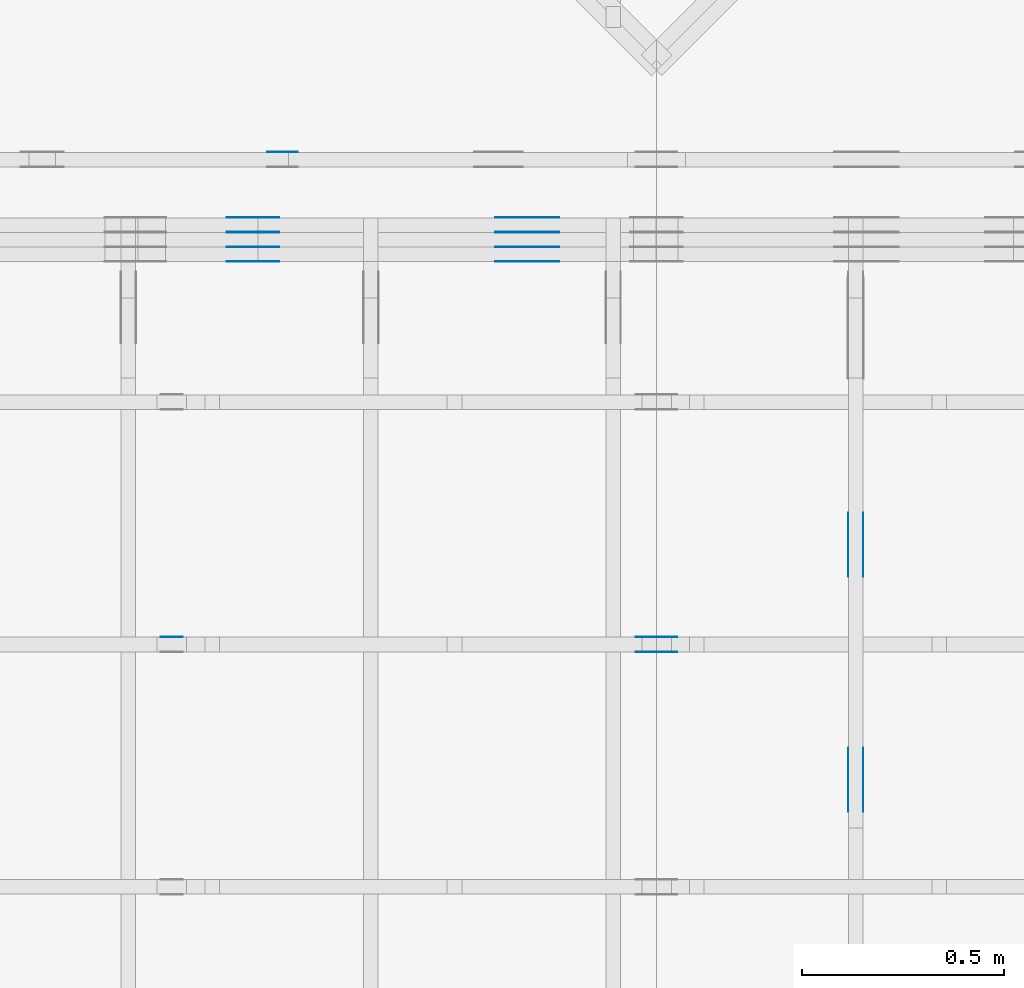
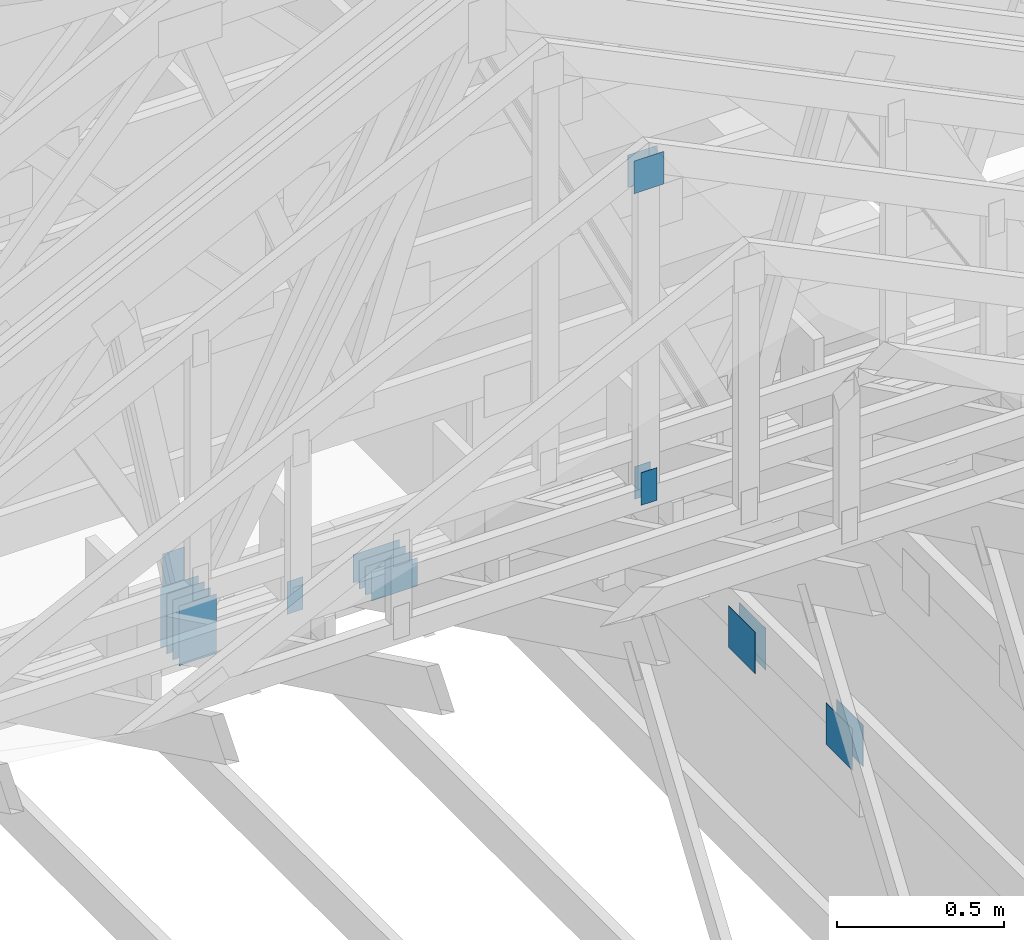
# One storey, part 102 of 159: 22 plates, 4 elements without a shape of their own.
"""IFC2X3 building model written with IfcOpenShell, lengths in millimetres."""

from ifc_helpers import new_model, si_unit, frame, origin, origin_with_axes, origin_2d, place, context, project, spatial, faceted_brep, element, aggregate, save


model = new_model("IFC2X3")

# Units and contexts
model_context = context("Model", 3, precision=1e-05, world=origin())
plan_context = context("Plan", 2, precision=1e-05, world=origin_2d())
ifc_project = project(units=[si_unit("LENGTHUNIT", "METRE", prefix="MILLI"), si_unit("AREAUNIT", "SQUARE_METRE"), si_unit("VOLUMEUNIT", "CUBIC_METRE"), si_unit("SOLIDANGLEUNIT", "STERADIAN"), si_unit("PLANEANGLEUNIT", "RADIAN"), si_unit("MASSUNIT", "GRAM"), si_unit("TIMEUNIT", "SECOND"), si_unit("THERMODYNAMICTEMPERATUREUNIT", "DEGREE_CELSIUS"), si_unit("LUMINOUSINTENSITYUNIT", "LUMEN")], contexts=[model_context, plan_context])

# Site, building, storey
site_placement = place(None, origin_with_axes())
site = spatial("IfcSite", under=ifc_project, at=site_placement, CompositionType="ELEMENT")
building_placement = place(site_placement, origin_with_axes())
building = spatial("IfcBuilding", under=site, at=building_placement, Name="Plan 1", CompositionType="ELEMENT")
storey_placement = place(building_placement, origin_with_axes())
storey = spatial("IfcBuildingStorey", under=building, at=storey_placement, Name="Etasje 1", CompositionType="ELEMENT", Elevation=0.0)

# Assembly, plates
assembly_1_placement = place(storey_placement, frame((10700.012663101485, 8801.999999990367, 0.0), z_axis=(0.0, -1.0, 6.123031769111886e-17), x_axis=(1.0, 0.0, 0.0)))
assembly_1 = element("IfcElementAssembly", 1, at=assembly_1_placement, inside=storey, Name="T8 (1)", AssemblyPlace="FACTORY", PredefinedType="TRUSS")
plate_1_placement = place(assembly_1_placement, frame((3659.5000000000005, 348.5, 0.0), z_axis=(0.0, 0.0, 1.0), x_axis=(-1.0, 1.2246063538223773e-16, 0.0)))
plate_1 = element("IfcPlate", 2, at=plate_1_placement, Name="GNT100S 103x159", context=model_context, shape_type="Brep", body=[
    faceted_brep([(159.00000000000045, 103.0, 1.0), (4.547473508864641e-13, 103.0, 1.0), (4.547473508864641e-13, 0.0, 1.0), (159.00000000000045, 0.0, 1.0), (4.547473508864641e-13, 103.0, 5.56886495279458e-29), (159.00000000000045, 103.0, 1.9471241025775855e-14), (159.00000000000045, 0.0, 1.9471241025775855e-14), (4.547473508864641e-13, 0.0, 5.56886495279458e-29), (159.0, 3.118536516261844e-13, 1.788345410772899e-30), (159.0, 3.119148819438755e-13, 1.0), (1.1247455413666031e-32, 3.411217434825392e-13, 1.0), (0.0, 3.410605131648481e-13, 0.0), (159.0, 103.00000000000037, 0.0), (159.0, 103.00000000000037, 1.0), (159.0, 3.410605131648481e-13, 1.0), (159.0, 3.410605131648481e-13, 0.0), (0.0, 103.00000000000034, 0.0), (0.0, 103.00000000000034, 1.0), (159.0, 103.00000000000037, 1.0), (159.0, 103.00000000000037, -7.888609052210118e-31), (4.176648714595935e-29, 3.410605131648481e-13, -2.5573752767891235e-45), (6.123031769116062e-17, 3.410605131648481e-13, 1.0), (1.2674675762061646e-14, 103.00000000000034, 1.0), (1.2613445444370527e-14, 103.00000000000034, -7.723252717384033e-31)], [[[0, 1, 2, 3]], [[4, 5, 6, 7]], [[8, 9, 10, 11]], [[12, 13, 14, 15]], [[16, 17, 18, 19]], [[20, 21, 22, 23]]]),
])
plate_2_placement = place(assembly_1_placement, frame((3659.5000000000005, 348.5, -37.0), z_axis=(0.0, 0.0, 1.0), x_axis=(-1.0, 1.2246063538223773e-16, 0.0)))
plate_2 = element("IfcPlate", 3, at=plate_2_placement, Name="GNT100S 103x159", context=model_context, shape_type="Brep", body=[
    faceted_brep([(159.00000000000045, 103.0, 1.0), (4.547473508864641e-13, 103.0, 1.0), (4.547473508864641e-13, 0.0, 1.0), (159.00000000000045, 0.0, 1.0), (4.547473508864641e-13, 103.0, 5.56886495279458e-29), (159.00000000000045, 103.0, 1.9471241025775855e-14), (159.00000000000045, 0.0, 1.9471241025775855e-14), (4.547473508864641e-13, 0.0, 5.56886495279458e-29), (159.0, 3.118536516261844e-13, 1.788345410772899e-30), (159.0, 3.119148819438755e-13, 1.0), (1.1247455413666031e-32, 3.411217434825392e-13, 1.0), (0.0, 3.410605131648481e-13, 0.0), (159.0, 103.00000000000037, 0.0), (159.0, 103.00000000000037, 1.0), (159.0, 3.410605131648481e-13, 1.0), (159.0, 3.410605131648481e-13, 0.0), (0.0, 103.00000000000034, 0.0), (0.0, 103.00000000000034, 1.0), (159.0, 103.00000000000037, 1.0), (159.0, 103.00000000000037, -7.888609052210118e-31), (4.176648714595935e-29, 3.410605131648481e-13, -2.5573752767891235e-45), (6.123031769116062e-17, 3.410605131648481e-13, 1.0), (1.2674675762061646e-14, 103.00000000000034, 1.0), (1.2613445444370527e-14, 103.00000000000034, -7.723252717384033e-31)], [[[0, 1, 2, 3]], [[4, 5, 6, 7]], [[8, 9, 10, 11]], [[12, 13, 14, 15]], [[16, 17, 18, 19]], [[20, 21, 22, 23]]]),
])
plate_3_placement = place(assembly_1_placement, frame((3659.5000000000005, 348.5, -36.0), z_axis=(0.0, 0.0, 1.0), x_axis=(-1.0, 1.2246063538223773e-16, 0.0)))
plate_3 = element("IfcPlate", 4, at=plate_3_placement, Name="GNT100S 103x159", context=model_context, shape_type="Brep", body=[
    faceted_brep([(159.00000000000045, 103.0, 1.0), (4.547473508864641e-13, 103.0, 1.0), (4.547473508864641e-13, 0.0, 1.0), (159.00000000000045, 0.0, 1.0), (4.547473508864641e-13, 103.0, 5.56886495279458e-29), (159.00000000000045, 103.0, 1.9471241025775855e-14), (159.00000000000045, 0.0, 1.9471241025775855e-14), (4.547473508864641e-13, 0.0, 5.56886495279458e-29), (159.0, 3.118536516261844e-13, 1.788345410772899e-30), (159.0, 3.119148819438755e-13, 1.0), (1.1247455413666031e-32, 3.411217434825392e-13, 1.0), (0.0, 3.410605131648481e-13, 0.0), (159.0, 103.00000000000037, 0.0), (159.0, 103.00000000000037, 1.0), (159.0, 3.410605131648481e-13, 1.0), (159.0, 3.410605131648481e-13, 0.0), (0.0, 103.00000000000034, 0.0), (0.0, 103.00000000000034, 1.0), (159.0, 103.00000000000037, 1.0), (159.0, 103.00000000000037, -7.888609052210118e-31), (4.176648714595935e-29, 3.410605131648481e-13, -2.5573752767891235e-45), (6.123031769116062e-17, 3.410605131648481e-13, 1.0), (1.2674675762061646e-14, 103.00000000000034, 1.0), (1.2613445444370527e-14, 103.00000000000034, -7.723252717384033e-31)], [[[0, 1, 2, 3]], [[4, 5, 6, 7]], [[8, 9, 10, 11]], [[12, 13, 14, 15]], [[16, 17, 18, 19]], [[20, 21, 22, 23]]]),
])
plate_4_placement = place(assembly_1_placement, frame((3659.5000000000005, 348.5, -73.0), z_axis=(0.0, 0.0, 1.0), x_axis=(-1.0, 1.2246063538223773e-16, 0.0)))
plate_4 = element("IfcPlate", 5, at=plate_4_placement, Name="GNT100S 103x159", context=model_context, shape_type="Brep", body=[
    faceted_brep([(159.00000000000045, 103.0, 1.0), (4.547473508864641e-13, 103.0, 1.0), (4.547473508864641e-13, 0.0, 1.0), (159.00000000000045, 0.0, 1.0), (4.547473508864641e-13, 103.0, 5.56886495279458e-29), (159.00000000000045, 103.0, 1.9471241025775855e-14), (159.00000000000045, 0.0, 1.9471241025775855e-14), (4.547473508864641e-13, 0.0, 5.56886495279458e-29), (159.0, 3.118536516261844e-13, 1.788345410772899e-30), (159.0, 3.119148819438755e-13, 1.0), (1.1247455413666031e-32, 3.411217434825392e-13, 1.0), (0.0, 3.410605131648481e-13, 0.0), (159.0, 103.00000000000037, 0.0), (159.0, 103.00000000000037, 1.0), (159.0, 3.410605131648481e-13, 1.0), (159.0, 3.410605131648481e-13, 0.0), (0.0, 103.00000000000034, 0.0), (0.0, 103.00000000000034, 1.0), (159.0, 103.00000000000037, 1.0), (159.0, 103.00000000000037, -7.888609052210118e-31), (4.176648714595935e-29, 3.410605131648481e-13, -2.5573752767891235e-45), (6.123031769116062e-17, 3.410605131648481e-13, 1.0), (1.2674675762061646e-14, 103.00000000000034, 1.0), (1.2613445444370527e-14, 103.00000000000034, -7.723252717384033e-31)], [[[0, 1, 2, 3]], [[4, 5, 6, 7]], [[8, 9, 10, 11]], [[12, 13, 14, 15]], [[16, 17, 18, 19]], [[20, 21, 22, 23]]]),
])
plate_5_placement = place(assembly_1_placement, frame((3659.5000000000005, 348.5, -72.0), z_axis=(0.0, 0.0, 1.0), x_axis=(-1.0, 1.2246063538223773e-16, 0.0)))
plate_5 = element("IfcPlate", 6, at=plate_5_placement, Name="GNT100S 103x159", context=model_context, shape_type="Brep", body=[
    faceted_brep([(159.00000000000045, 103.0, 1.0), (4.547473508864641e-13, 103.0, 1.0), (4.547473508864641e-13, 0.0, 1.0), (159.00000000000045, 0.0, 1.0), (4.547473508864641e-13, 103.0, 5.56886495279458e-29), (159.00000000000045, 103.0, 1.9471241025775855e-14), (159.00000000000045, 0.0, 1.9471241025775855e-14), (4.547473508864641e-13, 0.0, 5.56886495279458e-29), (159.0, 3.118536516261844e-13, 1.788345410772899e-30), (159.0, 3.119148819438755e-13, 1.0), (1.1247455413666031e-32, 3.411217434825392e-13, 1.0), (0.0, 3.410605131648481e-13, 0.0), (159.0, 103.00000000000037, 0.0), (159.0, 103.00000000000037, 1.0), (159.0, 3.410605131648481e-13, 1.0), (159.0, 3.410605131648481e-13, 0.0), (0.0, 103.00000000000034, 0.0), (0.0, 103.00000000000034, 1.0), (159.0, 103.00000000000037, 1.0), (159.0, 103.00000000000037, -7.888609052210118e-31), (4.176648714595935e-29, 3.410605131648481e-13, -2.5573752767891235e-45), (6.123031769116062e-17, 3.410605131648481e-13, 1.0), (1.2674675762061646e-14, 103.00000000000034, 1.0), (1.2613445444370527e-14, 103.00000000000034, -7.723252717384033e-31)], [[[0, 1, 2, 3]], [[4, 5, 6, 7]], [[8, 9, 10, 11]], [[12, 13, 14, 15]], [[16, 17, 18, 19]], [[20, 21, 22, 23]]]),
])
plate_6_placement = place(assembly_1_placement, frame((3659.5000000000005, 348.5, -109.0), z_axis=(0.0, 0.0, 1.0), x_axis=(-1.0, 1.2246063538223773e-16, 0.0)))
plate_6 = element("IfcPlate", 7, at=plate_6_placement, Name="GNT100S 103x159", context=model_context, shape_type="Brep", body=[
    faceted_brep([(159.00000000000045, 103.0, 1.0), (4.547473508864641e-13, 103.0, 1.0), (4.547473508864641e-13, 0.0, 1.0), (159.00000000000045, 0.0, 1.0), (4.547473508864641e-13, 103.0, 5.56886495279458e-29), (159.00000000000045, 103.0, 1.9471241025775855e-14), (159.00000000000045, 0.0, 1.9471241025775855e-14), (4.547473508864641e-13, 0.0, 5.56886495279458e-29), (159.0, 3.118536516261844e-13, 1.788345410772899e-30), (159.0, 3.119148819438755e-13, 1.0), (1.1247455413666031e-32, 3.411217434825392e-13, 1.0), (0.0, 3.410605131648481e-13, 0.0), (159.0, 103.00000000000037, 0.0), (159.0, 103.00000000000037, 1.0), (159.0, 3.410605131648481e-13, 1.0), (159.0, 3.410605131648481e-13, 0.0), (0.0, 103.00000000000034, 0.0), (0.0, 103.00000000000034, 1.0), (159.0, 103.00000000000037, 1.0), (159.0, 103.00000000000037, -7.888609052210118e-31), (4.176648714595935e-29, 3.410605131648481e-13, -2.5573752767891235e-45), (6.123031769116062e-17, 3.410605131648481e-13, 1.0), (1.2674675762061646e-14, 103.00000000000034, 1.0), (1.2613445444370527e-14, 103.00000000000034, -7.723252717384033e-31)], [[[0, 1, 2, 3]], [[4, 5, 6, 7]], [[8, 9, 10, 11]], [[12, 13, 14, 15]], [[16, 17, 18, 19]], [[20, 21, 22, 23]]]),
])
plate_7_placement = place(assembly_1_placement, frame((2966.17333984375, 241.79315185546847, 0.0), z_axis=(0.0, 0.0, 1.0), x_axis=(6.123031769111886e-17, 1.0, 0.0)))
plate_7 = element("IfcPlate", 8, at=plate_7_placement, Name="GNT100S 130x218", context=model_context, shape_type="Brep", body=[
    faceted_brep([(218.00000000000028, 130.0, 1.0), (2.8421709430404007e-13, 130.0, 1.0), (2.8421709430404007e-13, 0.0, 1.0), (218.00000000000028, 0.0, 1.0), (2.8421709430404007e-13, 130.0, 3.4805405954966126e-29), (218.00000000000028, 130.0, 2.669641851332786e-14), (218.00000000000028, 0.0, 2.669641851332786e-14), (2.8421709430404007e-13, 0.0, 3.4805405954966126e-29), (218.0, -4.0044627769991736e-14, 2.4519452801791947e-30), (218.0, -3.998339745230062e-14, 1.0), (1.1247455413666031e-32, 6.123031769111886e-17, 1.0), (0.0, 0.0, 0.0), (218.0, 130.0, 0.0), (218.0, 130.0, 1.0), (218.0, 0.0, 1.0), (218.0, 0.0, 0.0), (0.0, 130.0, 0.0), (-3.7491518045553436e-33, 130.0, 1.0), (218.0, 130.0, 1.0), (218.0, 130.0, -1.5777218104420236e-30), (0.0, 0.0, 0.0), (6.123031769111886e-17, -7.498303609110687e-33, 1.0), (1.5981112917382023e-14, 130.0, 1.0), (1.5919882599690904e-14, 130.0, -9.747794691843893e-31)], [[[0, 1, 2, 3]], [[4, 5, 6, 7]], [[8, 9, 10, 11]], [[12, 13, 14, 15]], [[16, 17, 18, 19]], [[20, 21, 22, 23]]]),
])
plate_8_placement = place(assembly_1_placement, frame((2966.17333984375, 241.79315185546847, -37.0), z_axis=(0.0, 0.0, 1.0), x_axis=(6.123031769111886e-17, 1.0, 0.0)))
plate_8 = element("IfcPlate", 9, at=plate_8_placement, Name="GNT100S 130x218", context=model_context, shape_type="Brep", body=[
    faceted_brep([(218.00000000000028, 130.0, 1.0), (2.8421709430404007e-13, 130.0, 1.0), (2.8421709430404007e-13, 0.0, 1.0), (218.00000000000028, 0.0, 1.0), (2.8421709430404007e-13, 130.0, 3.4805405954966126e-29), (218.00000000000028, 130.0, 2.669641851332786e-14), (218.00000000000028, 0.0, 2.669641851332786e-14), (2.8421709430404007e-13, 0.0, 3.4805405954966126e-29), (218.0, -4.0044627769991736e-14, 2.4519452801791947e-30), (218.0, -3.998339745230062e-14, 1.0), (1.1247455413666031e-32, 6.123031769111886e-17, 1.0), (0.0, 0.0, 0.0), (218.0, 130.0, 0.0), (218.0, 130.0, 1.0), (218.0, 0.0, 1.0), (218.0, 0.0, 0.0), (0.0, 130.0, 0.0), (-3.7491518045553436e-33, 130.0, 1.0), (218.0, 130.0, 1.0), (218.0, 130.0, -1.5777218104420236e-30), (0.0, 0.0, 0.0), (6.123031769111886e-17, -7.498303609110687e-33, 1.0), (1.5981112917382023e-14, 130.0, 1.0), (1.5919882599690904e-14, 130.0, -9.747794691843893e-31)], [[[0, 1, 2, 3]], [[4, 5, 6, 7]], [[8, 9, 10, 11]], [[12, 13, 14, 15]], [[16, 17, 18, 19]], [[20, 21, 22, 23]]]),
])
plate_9_placement = place(assembly_1_placement, frame((2966.17333984375, 241.79315185546847, -36.0), z_axis=(0.0, 0.0, 1.0), x_axis=(6.123031769111886e-17, 1.0, 0.0)))
plate_9 = element("IfcPlate", 10, at=plate_9_placement, Name="GNT100S 130x218", context=model_context, shape_type="Brep", body=[
    faceted_brep([(218.00000000000028, 130.0, 1.0), (2.8421709430404007e-13, 130.0, 1.0), (2.8421709430404007e-13, 0.0, 1.0), (218.00000000000028, 0.0, 1.0), (2.8421709430404007e-13, 130.0, 3.4805405954966126e-29), (218.00000000000028, 130.0, 2.669641851332786e-14), (218.00000000000028, 0.0, 2.669641851332786e-14), (2.8421709430404007e-13, 0.0, 3.4805405954966126e-29), (218.0, -4.0044627769991736e-14, 2.4519452801791947e-30), (218.0, -3.998339745230062e-14, 1.0), (1.1247455413666031e-32, 6.123031769111886e-17, 1.0), (0.0, 0.0, 0.0), (218.0, 130.0, 0.0), (218.0, 130.0, 1.0), (218.0, 0.0, 1.0), (218.0, 0.0, 0.0), (0.0, 130.0, 0.0), (-3.7491518045553436e-33, 130.0, 1.0), (218.0, 130.0, 1.0), (218.0, 130.0, -1.5777218104420236e-30), (0.0, 0.0, 0.0), (6.123031769111886e-17, -7.498303609110687e-33, 1.0), (1.5981112917382023e-14, 130.0, 1.0), (1.5919882599690904e-14, 130.0, -9.747794691843893e-31)], [[[0, 1, 2, 3]], [[4, 5, 6, 7]], [[8, 9, 10, 11]], [[12, 13, 14, 15]], [[16, 17, 18, 19]], [[20, 21, 22, 23]]]),
])
plate_10_placement = place(assembly_1_placement, frame((2966.17333984375, 241.79315185546847, -73.0), z_axis=(0.0, 0.0, 1.0), x_axis=(6.123031769111886e-17, 1.0, 0.0)))
plate_10 = element("IfcPlate", 11, at=plate_10_placement, Name="GNT100S 130x218", context=model_context, shape_type="Brep", body=[
    faceted_brep([(218.00000000000028, 130.0, 1.0), (2.8421709430404007e-13, 130.0, 1.0), (2.8421709430404007e-13, 0.0, 1.0), (218.00000000000028, 0.0, 1.0), (2.8421709430404007e-13, 130.0, 3.4805405954966126e-29), (218.00000000000028, 130.0, 2.669641851332786e-14), (218.00000000000028, 0.0, 2.669641851332786e-14), (2.8421709430404007e-13, 0.0, 3.4805405954966126e-29), (218.0, -4.0044627769991736e-14, 2.4519452801791947e-30), (218.0, -3.998339745230062e-14, 1.0), (1.1247455413666031e-32, 6.123031769111886e-17, 1.0), (0.0, 0.0, 0.0), (218.0, 130.0, 0.0), (218.0, 130.0, 1.0), (218.0, 0.0, 1.0), (218.0, 0.0, 0.0), (0.0, 130.0, 0.0), (-3.7491518045553436e-33, 130.0, 1.0), (218.0, 130.0, 1.0), (218.0, 130.0, -1.5777218104420236e-30), (0.0, 0.0, 0.0), (6.123031769111886e-17, -7.498303609110687e-33, 1.0), (1.5981112917382023e-14, 130.0, 1.0), (1.5919882599690904e-14, 130.0, -9.747794691843893e-31)], [[[0, 1, 2, 3]], [[4, 5, 6, 7]], [[8, 9, 10, 11]], [[12, 13, 14, 15]], [[16, 17, 18, 19]], [[20, 21, 22, 23]]]),
])
plate_11_placement = place(assembly_1_placement, frame((2966.17333984375, 241.79315185546847, -72.0), z_axis=(0.0, 0.0, 1.0), x_axis=(6.123031769111886e-17, 1.0, 0.0)))
plate_11 = element("IfcPlate", 12, at=plate_11_placement, Name="GNT100S 130x218", context=model_context, shape_type="Brep", body=[
    faceted_brep([(218.00000000000028, 130.0, 1.0), (2.8421709430404007e-13, 130.0, 1.0), (2.8421709430404007e-13, 0.0, 1.0), (218.00000000000028, 0.0, 1.0), (2.8421709430404007e-13, 130.0, 3.4805405954966126e-29), (218.00000000000028, 130.0, 2.669641851332786e-14), (218.00000000000028, 0.0, 2.669641851332786e-14), (2.8421709430404007e-13, 0.0, 3.4805405954966126e-29), (218.0, -4.0044627769991736e-14, 2.4519452801791947e-30), (218.0, -3.998339745230062e-14, 1.0), (1.1247455413666031e-32, 6.123031769111886e-17, 1.0), (0.0, 0.0, 0.0), (218.0, 130.0, 0.0), (218.0, 130.0, 1.0), (218.0, 0.0, 1.0), (218.0, 0.0, 0.0), (0.0, 130.0, 0.0), (-3.7491518045553436e-33, 130.0, 1.0), (218.0, 130.0, 1.0), (218.0, 130.0, -1.5777218104420236e-30), (0.0, 0.0, 0.0), (6.123031769111886e-17, -7.498303609110687e-33, 1.0), (1.5981112917382023e-14, 130.0, 1.0), (1.5919882599690904e-14, 130.0, -9.747794691843893e-31)], [[[0, 1, 2, 3]], [[4, 5, 6, 7]], [[8, 9, 10, 11]], [[12, 13, 14, 15]], [[16, 17, 18, 19]], [[20, 21, 22, 23]]]),
])
plate_12_placement = place(assembly_1_placement, frame((2966.17333984375, 241.79315185546847, -109.0), z_axis=(0.0, 0.0, 1.0), x_axis=(6.123031769111886e-17, 1.0, 0.0)))
plate_12 = element("IfcPlate", 13, at=plate_12_placement, Name="GNT100S 130x218", context=model_context, shape_type="Brep", body=[
    faceted_brep([(218.00000000000028, 130.0, 1.0), (2.8421709430404007e-13, 130.0, 1.0), (2.8421709430404007e-13, 0.0, 1.0), (218.00000000000028, 0.0, 1.0), (2.8421709430404007e-13, 130.0, 3.4805405954966126e-29), (218.00000000000028, 130.0, 2.669641851332786e-14), (218.00000000000028, 0.0, 2.669641851332786e-14), (2.8421709430404007e-13, 0.0, 3.4805405954966126e-29), (218.0, -4.0044627769991736e-14, 2.4519452801791947e-30), (218.0, -3.998339745230062e-14, 1.0), (1.1247455413666031e-32, 6.123031769111886e-17, 1.0), (0.0, 0.0, 0.0), (218.0, 130.0, 0.0), (218.0, 130.0, 1.0), (218.0, 0.0, 1.0), (218.0, 0.0, 0.0), (0.0, 130.0, 0.0), (-3.7491518045553436e-33, 130.0, 1.0), (218.0, 130.0, 1.0), (218.0, 130.0, -1.5777218104420236e-30), (0.0, 0.0, 0.0), (6.123031769111886e-17, -7.498303609110687e-33, 1.0), (1.5981112917382023e-14, 130.0, 1.0), (1.5919882599690904e-14, 130.0, -9.747794691843893e-31)], [[[0, 1, 2, 3]], [[4, 5, 6, 7]], [[8, 9, 10, 11]], [[12, 13, 14, 15]], [[16, 17, 18, 19]], [[20, 21, 22, 23]]]),
])
aggregate(assembly_1, [plate_1, plate_2, plate_3, plate_4, plate_5, plate_6, plate_7, plate_8, plate_9, plate_10, plate_11, plate_12])

# Assembly, plate
assembly_2_placement = place(storey_placement, frame((10000.012663278096, 9072.000080051337, 1.1021457184401395e-15), z_axis=(9.811600543477555e-09, 1.0, 6.123031769111886e-17), x_axis=(-1.0, 9.811600543477555e-09, 0.0)))
assembly_2 = element("IfcElementAssembly", 14, at=assembly_2_placement, inside=storey, Name="T9 (79)", AssemblyPlace="FACTORY", PredefinedType="TRUSS")
plate_13_placement = place(assembly_2_placement, frame((-3636.319824218732, 291.5, 0.0), z_axis=(0.0, 0.0, 1.0), x_axis=(6.123031769111886e-17, 1.0, 0.0)))
plate_13 = element("IfcPlate", 15, at=plate_13_placement, Name="GNT100S 76x159", context=model_context, shape_type="Brep", body=[
    faceted_brep([(159.0, 76.00000000001819, 1.0), (0.0, 76.00000000001819, 1.0), (0.0, 1.8189894035458565e-11, 1.0), (159.0, 1.8189894035458565e-11, 1.0), (0.0, 76.00000000001819, 0.0), (159.0, 76.00000000001819, 1.9471241025775798e-14), (159.0, 1.8189894035458565e-11, 1.9471241025775798e-14), (0.0, 1.8189894035458565e-11, 0.0), (159.00000000000045, -2.920686153866378e-14, 1.788345410772904e-30), (159.00000000000045, -2.914563122097266e-14, 1.0), (4.547473508864641e-13, 6.123031769103533e-17, 1.0), (4.547473508864641e-13, -8.35329742919187e-29, 5.114750553578247e-45), (159.00000000000045, 76.0, 0.0), (159.00000000000045, 76.0, 1.0), (159.00000000000045, 0.0, 1.0), (159.00000000000045, 0.0, 0.0), (4.547473508864641e-13, 76.0, 0.0), (4.547473508864641e-13, 76.0, 1.0), (159.00000000000045, 75.99999999999999, 1.0), (159.00000000000045, 75.99999999999999, -7.888609052210118e-31), (4.547473508864641e-13, 0.0, 0.0), (4.548085812041552e-13, -7.498303609110687e-33, 1.0), (4.641155894932053e-13, 76.0, 1.0), (4.640543591755142e-13, 76.0, -5.698710742924122e-31)], [[[0, 1, 2, 3]], [[4, 5, 6, 7]], [[8, 9, 10, 11]], [[12, 13, 14, 15]], [[16, 17, 18, 19]], [[20, 21, 22, 23]]]),
])
aggregate(assembly_2, [plate_13])

# Assembly, plates
assembly_3_placement = place(storey_placement, frame((15075.02226140475, -699.9989301294845, 1.1021457184401395e-15), z_axis=(-1.0, 1.836909530733566e-16, 6.123031769111886e-17), x_axis=(-1.836909530733566e-16, -1.0, 0.0)))
assembly_3 = element("IfcElementAssembly", 16, at=assembly_3_placement, inside=storey, Name="T7 (103)", AssemblyPlace="FACTORY", PredefinedType="TRUSS")
plate_14_placement = place(assembly_3_placement, frame((-8880.4990234375, 147.0, 0.0), z_axis=(0.0, 0.0, 1.0), x_axis=(1.0, 0.0, 0.0)))
plate_14 = element("IfcPlate", 17, at=plate_14_placement, Name="GNT100S 152x159", context=model_context, shape_type="Brep", body=[
    faceted_brep([(159.0, 152.0, 1.0), (0.0, 152.0, 1.0), (0.0, 0.0, 1.0), (159.0, 0.0, 1.0), (0.0, 152.0, 0.0), (159.0, 152.0, 1.9471241025775798e-14), (159.0, 0.0, 1.9471241025775798e-14), (0.0, 0.0, 0.0), (159.00009331759065, -2.9206878680260863e-14, 1.7883464603583392e-30), (159.00009331759065, -2.9145648362569744e-14, 1.0), (9.331759065389633e-05, 6.121317609395314e-17, 1.0), (9.331759065389633e-05, -1.714159716572357e-20, 1.0495854401904369e-36), (159.00009331759065, 152.0, 0.0), (159.00009331759065, 152.0, 1.0), (159.00009331759065, 0.0, 1.0), (159.00009331759065, 0.0, 0.0), (9.331759065389633e-05, 152.0, 0.0), (9.331759065389633e-05, 152.0, 1.0), (159.00009331759065, 152.0, 1.0), (159.00009331759065, 152.0, 0.0), (9.331759065389633e-05, 0.0, 0.0), (9.331759065395756e-05, -7.498303609110687e-33, 1.0), (9.331759067257158e-05, 152.0, 1.0), (9.331759067251035e-05, 152.0, -1.1397420192804459e-30)], [[[0, 1, 2, 3]], [[4, 5, 6, 7]], [[8, 9, 10, 11]], [[12, 13, 14, 15]], [[16, 17, 18, 19]], [[20, 21, 22, 23]]]),
])
plate_15_placement = place(assembly_3_placement, frame((-8880.4990234375, 147.0, -37.0), z_axis=(0.0, 0.0, 1.0), x_axis=(1.0, 0.0, 0.0)))
plate_15 = element("IfcPlate", 18, at=plate_15_placement, Name="GNT100S 152x159", context=model_context, shape_type="Brep", body=[
    faceted_brep([(159.0, 152.0, 1.0), (0.0, 152.0, 1.0), (0.0, 0.0, 1.0), (159.0, 0.0, 1.0), (0.0, 152.0, 0.0), (159.0, 152.0, 1.9471241025775798e-14), (159.0, 0.0, 1.9471241025775798e-14), (0.0, 0.0, 0.0), (159.00009331759065, -2.9206878680260863e-14, 1.7883464603583392e-30), (159.00009331759065, -2.9145648362569744e-14, 1.0), (9.331759065389633e-05, 6.121317609395314e-17, 1.0), (9.331759065389633e-05, -1.714159716572357e-20, 1.0495854401904369e-36), (159.00009331759065, 152.0, 0.0), (159.00009331759065, 152.0, 1.0), (159.00009331759065, 0.0, 1.0), (159.00009331759065, 0.0, 0.0), (9.331759065389633e-05, 152.0, 0.0), (9.331759065389633e-05, 152.0, 1.0), (159.00009331759065, 152.0, 1.0), (159.00009331759065, 152.0, 0.0), (9.331759065389633e-05, 0.0, 0.0), (9.331759065395756e-05, -7.498303609110687e-33, 1.0), (9.331759067257158e-05, 152.0, 1.0), (9.331759067251035e-05, 152.0, -1.1397420192804459e-30)], [[[0, 1, 2, 3]], [[4, 5, 6, 7]], [[8, 9, 10, 11]], [[12, 13, 14, 15]], [[16, 17, 18, 19]], [[20, 21, 22, 23]]]),
])
plate_16_placement = place(assembly_3_placement, frame((-8139.998930119909, 299.0, 0.0), z_axis=(0.0, 0.0, 1.0), x_axis=(-1.0, 1.2246063538223773e-16, 0.0)))
plate_16 = element("IfcPlate", 19, at=plate_16_placement, Name="GNT100S 152x159", context=model_context, shape_type="Brep", body=[
    faceted_brep([(159.00009331759065, 151.99999999999997, 1.0), (9.331759065389633e-05, 151.99999999999997, 1.0), (9.331759065389633e-05, 0.0, 1.0), (159.00009331759065, 0.0, 1.0), (9.331759065389633e-05, 151.99999999999997, 1.1427731443815714e-20), (159.00009331759065, 151.99999999999997, 1.9471252453507242e-14), (159.00009331759065, 0.0, 1.9471252453507242e-14), (9.331759065389633e-05, 0.0, 1.1427731443815714e-20), (159.0, -2.92068615386637e-14, 1.788345410772899e-30), (159.0, -2.914563122097258e-14, 1.0), (1.1247455413666031e-32, 6.123031769111886e-17, 1.0), (0.0, 0.0, 0.0), (159.0, 152.0, 0.0), (159.0, 152.0, 1.0), (159.0, 0.0, 1.0), (159.0, 0.0, 0.0), (0.0, 151.99999999999997, 0.0), (0.0, 151.99999999999997, 1.0), (159.0, 152.0, 1.0), (159.0, 152.0, 0.0), (0.0, 0.0, 0.0), (6.123031769111886e-17, -7.498303609110687e-33, 1.0), (1.867524689579125e-14, 151.99999999999997, 1.0), (1.861401657810013e-14, 151.99999999999997, -1.1397421485848243e-30)], [[[0, 1, 2, 3]], [[4, 5, 6, 7]], [[8, 9, 10, 11]], [[12, 13, 14, 15]], [[16, 17, 18, 19]], [[20, 21, 22, 23]]]),
])
plate_17_placement = place(assembly_3_placement, frame((-8139.998930119909, 299.0, -37.0), z_axis=(0.0, 0.0, 1.0), x_axis=(-1.0, 1.2246063538223773e-16, 0.0)))
plate_17 = element("IfcPlate", 20, at=plate_17_placement, Name="GNT100S 152x159", context=model_context, shape_type="Brep", body=[
    faceted_brep([(159.00009331759065, 151.99999999999997, 1.0), (9.331759065389633e-05, 151.99999999999997, 1.0), (9.331759065389633e-05, 0.0, 1.0), (159.00009331759065, 0.0, 1.0), (9.331759065389633e-05, 151.99999999999997, 1.1427731443815714e-20), (159.00009331759065, 151.99999999999997, 1.9471252453507242e-14), (159.00009331759065, 0.0, 1.9471252453507242e-14), (9.331759065389633e-05, 0.0, 1.1427731443815714e-20), (159.0, -2.92068615386637e-14, 1.788345410772899e-30), (159.0, -2.914563122097258e-14, 1.0), (1.1247455413666031e-32, 6.123031769111886e-17, 1.0), (0.0, 0.0, 0.0), (159.0, 152.0, 0.0), (159.0, 152.0, 1.0), (159.0, 0.0, 1.0), (159.0, 0.0, 0.0), (0.0, 151.99999999999997, 0.0), (0.0, 151.99999999999997, 1.0), (159.0, 152.0, 1.0), (159.0, 152.0, 0.0), (0.0, 0.0, 0.0), (6.123031769111886e-17, -7.498303609110687e-33, 1.0), (1.867524689579125e-14, 151.99999999999997, 1.0), (1.861401657810013e-14, 151.99999999999997, -1.1397421485848243e-30)], [[[0, 1, 2, 3]], [[4, 5, 6, 7]], [[8, 9, 10, 11]], [[12, 13, 14, 15]], [[16, 17, 18, 19]], [[20, 21, 22, 23]]]),
])
aggregate(assembly_3, [plate_14, plate_15, plate_16, plate_17])

assembly_4_placement = place(storey_placement, frame((11846.012601162385, 7836.000061939094, 1020.3543282828622), z_axis=(0.0, -1.0, 6.123031769111886e-17), x_axis=(1.0, 0.0, 0.0)))
assembly_4 = element("IfcElementAssembly", 21, at=assembly_4_placement, inside=storey, Name="Tr2 (1)", AssemblyPlace="FACTORY", PredefinedType="TRUSS")
plate_18_placement = place(assembly_4_placement, frame((2702.5, 1293.6805889550596, 0.0), z_axis=(0.0, 0.0, 1.0), x_axis=(6.123031769111886e-17, -1.0, 0.0)))
plate_18 = element("IfcPlate", 22, at=plate_18_placement, Name="GNT100S 103x119", context=model_context, shape_type="Brep", body=[
    faceted_brep([(119.00004696287215, 103.0, 1.0), (4.696287214756012e-05, 103.0, 1.0), (4.696287214756012e-05, 0.0, 1.0), (119.00004696287215, 0.0, 1.0), (4.696287214756012e-05, 103.0, 5.7511031625650074e-21), (119.00004696287215, 103.0, 1.4572821361589452e-14), (119.00004696287215, 0.0, 1.4572821361589452e-14), (4.696287214756012e-05, 0.0, 5.7511031625650074e-21), (119.0, 6.193909801001203e-05, 1.3384468320270608e-30), (119.0, 6.193909801007326e-05, 1.0), (1.1247455413666031e-32, 6.193909803193248e-05, 1.0), (0.0, 6.193909803187125e-05, 0.0), (119.0, 103.00006193909803, 0.0), (119.0, 103.00006193909803, 1.0), (119.0, 6.193909803187125e-05, 1.0), (119.0, 6.193909803187125e-05, 0.0), (-4.861730685829017e-63, 103.00006193909803, 0.0), (-3.7491518045553436e-33, 103.00006193909803, 1.0), (119.0, 103.00006193909802, 1.0), (119.0, 103.00006193909802, -7.888609052210118e-31), (7.585101299985664e-21, 6.193909803187125e-05, -4.644381623174409e-37), (6.123790279241885e-17, 6.193909803187125e-05, 1.0), (1.2674683347162905e-14, 103.00006193909803, 1.0), (1.2613453029471786e-14, 103.00006193909803, -7.723257361765631e-31)], [[[0, 1, 2, 3]], [[4, 5, 6, 7]], [[8, 9, 10, 11]], [[12, 13, 14, 15]], [[16, 17, 18, 19]], [[20, 21, 22, 23]]]),
])
plate_19_placement = place(assembly_4_placement, frame((2702.5, 1293.6805889550596, -37.0), z_axis=(0.0, 0.0, 1.0), x_axis=(6.123031769111886e-17, -1.0, 0.0)))
plate_19 = element("IfcPlate", 23, at=plate_19_placement, Name="GNT100S 103x119", context=model_context, shape_type="Brep", body=[
    faceted_brep([(119.00004696287215, 103.0, 1.0), (4.696287214756012e-05, 103.0, 1.0), (4.696287214756012e-05, 0.0, 1.0), (119.00004696287215, 0.0, 1.0), (4.696287214756012e-05, 103.0, 5.7511031625650074e-21), (119.00004696287215, 103.0, 1.4572821361589452e-14), (119.00004696287215, 0.0, 1.4572821361589452e-14), (4.696287214756012e-05, 0.0, 5.7511031625650074e-21), (119.0, 6.193909801001203e-05, 1.3384468320270608e-30), (119.0, 6.193909801007326e-05, 1.0), (1.1247455413666031e-32, 6.193909803193248e-05, 1.0), (0.0, 6.193909803187125e-05, 0.0), (119.0, 103.00006193909803, 0.0), (119.0, 103.00006193909803, 1.0), (119.0, 6.193909803187125e-05, 1.0), (119.0, 6.193909803187125e-05, 0.0), (-4.861730685829017e-63, 103.00006193909803, 0.0), (-3.7491518045553436e-33, 103.00006193909803, 1.0), (119.0, 103.00006193909802, 1.0), (119.0, 103.00006193909802, -7.888609052210118e-31), (7.585101299985664e-21, 6.193909803187125e-05, -4.644381623174409e-37), (6.123790279241885e-17, 6.193909803187125e-05, 1.0), (1.2674683347162905e-14, 103.00006193909803, 1.0), (1.2613453029471786e-14, 103.00006193909803, -7.723257361765631e-31)], [[[0, 1, 2, 3]], [[4, 5, 6, 7]], [[8, 9, 10, 11]], [[12, 13, 14, 15]], [[16, 17, 18, 19]], [[20, 21, 22, 23]]]),
])
plate_20_placement = place(assembly_4_placement, frame((1581.5001220703127, 29.720829010009766, -37.0), z_axis=(0.0, 0.0, 1.0), x_axis=(-1.0489927069340377e-15, 1.0, 0.0)))
plate_20 = element("IfcPlate", 24, at=plate_20_placement, Name="GNT100S 55x119", context=model_context, shape_type="Brep", body=[
    faceted_brep([(118.9999961853028, 55.00000000000023, 1.0), (5.684341886080802e-14, 55.00000000000023, 1.0), (0.0, 2.2737367544323206e-13, 1.0), (118.99999618530275, 2.2737367544323206e-13, 1.0), (5.684341886080802e-14, 55.00000000000023, 6.961081190993225e-30), (118.9999961853028, 55.00000000000023, 1.4572815143336048e-14), (118.99999618530275, 0.0, 1.4572815143336042e-14), (0.0, 0.0, 0.0), (119.00000002035226, 6.01312146736432e-05, 1.3384468320270608e-30), (119.00000002035226, 6.013121467370443e-05, 1.0), (2.0352246110633132e-08, 6.013121469556365e-05, 1.0), (2.0352246110633132e-08, 6.013121469550242e-05, 0.0), (119.00000002035226, 55.000060131214696, 0.0), (119.00000002035226, 55.000060131214696, 1.0), (119.00000002035226, 6.013121469550242e-05, 1.0), (119.00000002035226, 6.013121469550242e-05, 0.0), (2.0352246110633132e-08, 55.000060131214696, 0.0), (2.0352246110633132e-08, 55.000060131214696, 1.0), (119.00000002035226, 55.00006013121469, 1.0), (119.00000002035226, 55.00006013121469, -3.944304526105059e-31), (2.0352246110640497e-08, 6.013121469550242e-05, -4.5091228613573685e-37), (2.0352246171870815e-08, 6.013121469550242e-05, 1.0), (2.035225290720576e-08, 55.000060131214696, 1.0), (2.0352252845975443e-08, 55.000060131214696, -4.124071494133739e-31)], [[[0, 1, 2, 3]], [[4, 5, 6, 7]], [[8, 9, 10, 11]], [[12, 13, 14, 15]], [[16, 17, 18, 19]], [[20, 21, 22, 23]]]),
])
plate_21_placement = place(assembly_4_placement, frame((2781.5000619390985, 29.720829010009766, 0.0), z_axis=(0.0, 0.0, 1.0), x_axis=(-3.8285889215894375e-16, 1.0, 0.0)))
plate_21 = element("IfcPlate", 25, at=plate_21_placement, Name="GNT100S 55x119", context=model_context, shape_type="Brep", body=[
    faceted_brep([(118.99999618530275, 55.00006193909849, 1.0), (2.1316282072803006e-14, 55.00006193909849, 1.0), (0.0, 6.19390984866186e-05, 1.0), (118.99999618530275, 6.19390984866186e-05, 1.0), (2.1316282072803006e-14, 55.00006193909849, 2.6104054466224595e-30), (118.99999618530275, 55.00006193909849, 1.4572815143336042e-14), (118.99999618530275, 6.19390984866186e-05, 1.4572815143336042e-14), (0.0, 6.19390984866186e-05, 0.0), (119.00000002023243, -2.185922341944595e-14, 1.338447194453821e-30), (119.00000002023243, -2.179799310175483e-14, 1.0), (2.0232430841815585e-08, 6.123031397460436e-17, 1.0), (2.0232430841815585e-08, -3.716514504323879e-24, 2.2756336380340227e-40), (119.00000002023243, 55.0, 1.5777218104420236e-30), (119.00000002023243, 55.0, 1.0), (119.00000002023243, 0.0, 1.0), (119.00000002023243, 0.0, 0.0), (2.0232430841815585e-08, 55.0, 0.0), (2.0232430841815585e-08, 55.0, 1.0), (119.0000000202324, 54.99999999999999, 1.0), (119.0000000202324, 54.99999999999999, -3.944304526105059e-31), (2.0232430841815585e-08, 0.0, 0.0), (2.0232430903045903e-08, -7.498303609110687e-33, 1.0), (2.023243763838085e-08, 55.0, 1.0), (2.023243757715053e-08, 55.0, -4.124066985010878e-31)], [[[0, 1, 2, 3]], [[4, 5, 6, 7]], [[8, 9, 10, 11]], [[12, 13, 14, 15]], [[16, 17, 18, 19]], [[20, 21, 22, 23]]]),
])
plate_22_placement = place(assembly_4_placement, frame((2781.5000619390985, 29.720829010009766, -37.0), z_axis=(0.0, 0.0, 1.0), x_axis=(-3.8285889215894375e-16, 1.0, 0.0)))
plate_22 = element("IfcPlate", 26, at=plate_22_placement, Name="GNT100S 55x119", context=model_context, shape_type="Brep", body=[
    faceted_brep([(118.99999618530275, 55.00006193909849, 1.0), (2.1316282072803006e-14, 55.00006193909849, 1.0), (0.0, 6.19390984866186e-05, 1.0), (118.99999618530275, 6.19390984866186e-05, 1.0), (2.1316282072803006e-14, 55.00006193909849, 2.6104054466224595e-30), (118.99999618530275, 55.00006193909849, 1.4572815143336042e-14), (118.99999618530275, 6.19390984866186e-05, 1.4572815143336042e-14), (0.0, 6.19390984866186e-05, 0.0), (119.00000002023243, -2.185922341944595e-14, 1.338447194453821e-30), (119.00000002023243, -2.179799310175483e-14, 1.0), (2.0232430841815585e-08, 6.123031397460436e-17, 1.0), (2.0232430841815585e-08, -3.716514504323879e-24, 2.2756336380340227e-40), (119.00000002023243, 55.0, 1.5777218104420236e-30), (119.00000002023243, 55.0, 1.0), (119.00000002023243, 0.0, 1.0), (119.00000002023243, 0.0, 0.0), (2.0232430841815585e-08, 55.0, 0.0), (2.0232430841815585e-08, 55.0, 1.0), (119.0000000202324, 54.99999999999999, 1.0), (119.0000000202324, 54.99999999999999, -3.944304526105059e-31), (2.0232430841815585e-08, 0.0, 0.0), (2.0232430903045903e-08, -7.498303609110687e-33, 1.0), (2.023243763838085e-08, 55.0, 1.0), (2.023243757715053e-08, 55.0, -4.124066985010878e-31)], [[[0, 1, 2, 3]], [[4, 5, 6, 7]], [[8, 9, 10, 11]], [[12, 13, 14, 15]], [[16, 17, 18, 19]], [[20, 21, 22, 23]]]),
])
aggregate(assembly_4, [plate_18, plate_19, plate_20, plate_21, plate_22])

save(model, "model.ifc")
